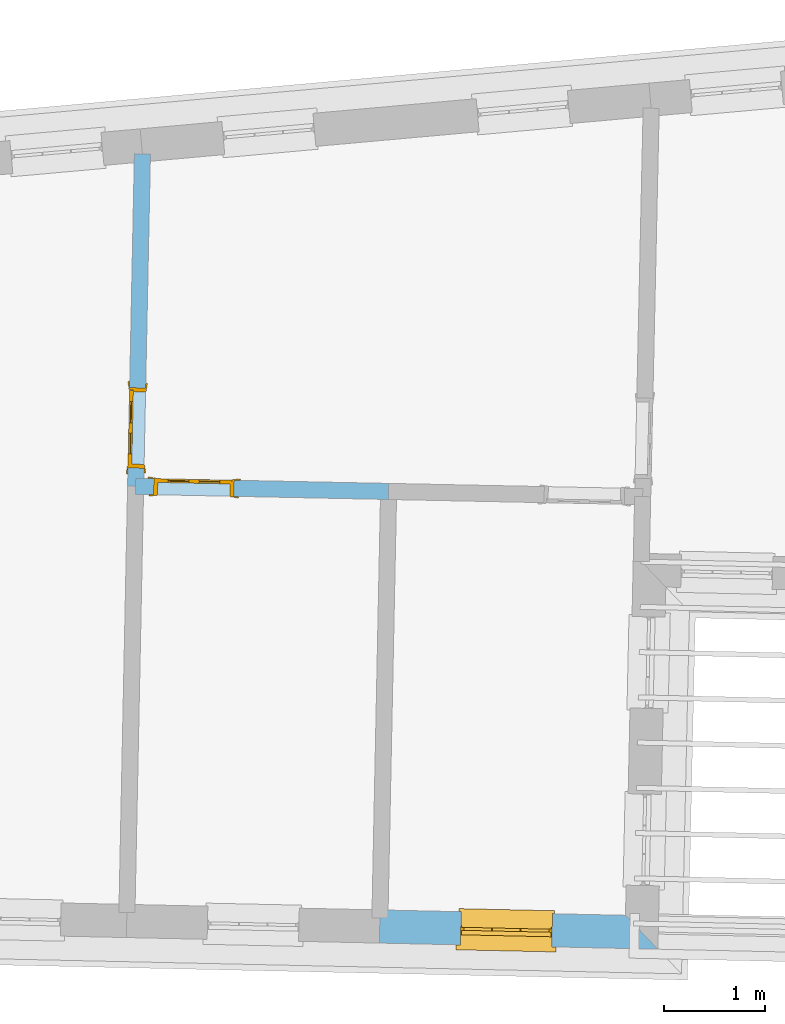
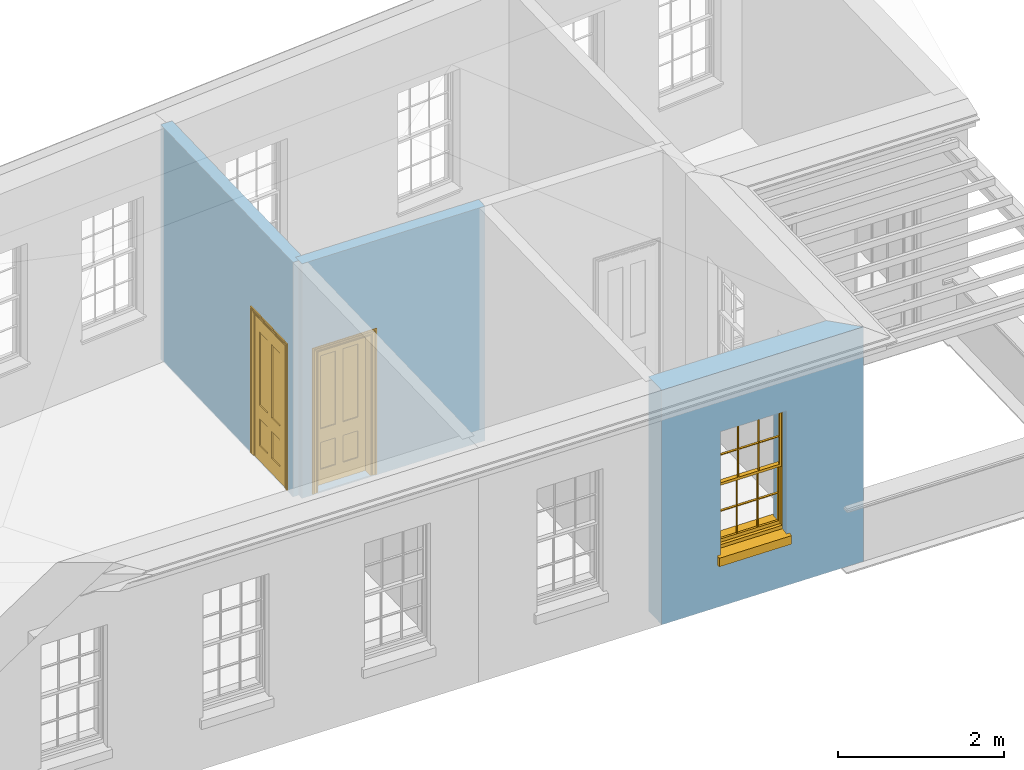
# One storey, part 7 of 14: 2 doors, 1 window, 3 openings, plus 3 elements that do not belong to this part.
"""IFC2X3 building model written with IfcOpenShell, lengths in metres."""

from ifc_helpers import new_model, si_unit, frame, origin, place, context, subcontext, project, spatial, polyline, outline, extrude, faceted_brep, material, layer, layer_set, layer_usage, element, fill, save


model = new_model("IFC2X3")

# Units and contexts
model_context = context("Model", 3, world=origin())
body_context = subcontext(model_context, "Body", "Model", "MODEL_VIEW")
ifc_project = project(units=[si_unit("PLANEANGLEUNIT", "RADIAN"), si_unit("MASSUNIT", "GRAM", prefix="KILO"), si_unit("FORCEUNIT", "NEWTON", prefix="KILO"), si_unit("LENGTHUNIT", "METRE")], contexts=[model_context])

# Site, building, storey
site_placement = place(None, origin())
site = spatial("IfcSite", under=ifc_project, at=site_placement, CompositionType="ELEMENT")
building_placement = place(None, origin())
building = spatial("IfcBuilding", under=site, at=building_placement, Name="Building plot-17", CompositionType="ELEMENT")
storey_placement = place(None, frame((0.0, 0.0, 6.15)))
storey = spatial("IfcBuildingStorey", under=building, at=storey_placement, Name="Floor 1", CompositionType="ELEMENT", Elevation=6.15)

# Wall, opening, window
ifc_material_1 = material(Name="Masonry")
ifc_layer_1 = layer(ifc_material_1, 0.33, ventilated=False)
ifc_layer_set_1 = layer_set([ifc_layer_1], Name="My Wall")
ifc_layer_usage_1 = layer_usage(ifc_layer_set_1, "AXIS2", "NEGATIVE", 0.08)
wall_1_placement = place(storey_placement, origin())
wall_1 = element("IfcWallStandardCase", 1, at=wall_1_placement, inside=storey, material=ifc_layer_usage_1, Name="exterior", context=body_context, shape_type="SweptSolid", body=[
    extrude(outline(polyline([(79.8085356769737, 18.6202146770249), (79.8013195426945, 18.2902935843284), (82.5720901936845, 18.2296904476484), (82.2493852352671, 18.5668276746241), (79.8085356769737, 18.6202146770249)])), origin(), (0.0, 0.0, 1.0), 3.45),
])
opening_1_placement = place(storey_placement, frame((0.0, 0.0, 0.75)))
opening_1 = element("IfcOpeningElement", 2, at=opening_1_placement, cuts=wall_1, Name="Opening", ObjectType="Opening", context=body_context, shape_type="SweptSolid", body=[
    extrude(outline(polyline([(80.6068435537532, 18.2726749186609), (81.516625960886, 18.2527758817093), (81.5238420951652, 18.5826969744058), (80.6140596880323, 18.6025960113574), (80.6068435537532, 18.2726749186609)])), origin(), (0.0, 0.0, 1.0), 1.82),
])
window_placement = place(storey_placement, frame((80.6123103221465, 18.5226151404007, 0.75), z_axis=(0.0, 0.0, 1.0), x_axis=(0.909782407132838, -0.0198990369516245, 0.0)))
window = element("IfcWindow", 3, at=window_placement, inside=storey, Name="toilet outside window", OverallHeight=1.82, OverallWidth=0.91, context=body_context, shape_type="Brep", held_by="IfcProductRepresentation", body=[
    faceted_brep([(0.033125, -0.105, 0.975209), (0.01, -0.105, 0.975209), (0.033125, -0.105, 1.376042), (0.876875, -0.105, 0.975209), (0.876875, -0.105, 1.376042), (0.9, -0.105, 0.975209), (0.876875, -0.105, 1.386042), (0.876875, -0.105, 1.786875), (0.9, -0.105, 1.81), (0.033125, -0.105, 1.786875), (0.033125, -0.105, 1.386042), (0.01, -0.105, 1.81), (0.876875, -0.135, 1.376042), (0.876875, -0.135, 0.975209), (0.9, -0.135, 0.937083), (0.033125, -0.135, 1.786875), (0.01, -0.135, 1.81), (0.033125, -0.135, 1.386042), (0.01, -0.135, 0.937083), (0.033125, -0.135, 0.975209), (0.033125, -0.135, 1.376042), (0.876875, -0.135, 1.786875), (0.876875, -0.135, 1.386042), (0.9, -0.135, 1.81), (0.033125, -0.105, 0.937083), (0.01, -0.105, 0.937083), (0.033125, -0.105, 0.53625), (0.876875, -0.105, 0.937083), (0.876875, -0.105, 0.53625), (0.9, -0.105, 0.937083), (0.876875, -0.105, 0.52625), (0.876875, -0.105, 0.125417), (0.9, -0.105, 0.077167), (0.033125, -0.105, 0.125417), (0.033125, -0.105, 0.52625), (0.01, -0.105, 0.077167), (-0.0425, -0.25, 0.01), (-0.0425, -0.3, 0.001667), (0.0, -0.25, 0.01), (0.9525, -0.25, 0.01), (0.91, -0.25, 0.01), (0.9525, -0.3, 0.001667), (-0.02, 0.08, 0.077167), (0.0, 0.08, 0.077167), (-0.02, 0.11, 0.077167), (0.0, -0.06, 0.077167), (0.01, -0.06, 0.077167), (0.91, -0.06, 0.077167), (0.91, 0.08, 0.077167), (0.9, -0.06, 0.077167), (0.93, 0.08, 0.077167), (0.93, 0.11, 0.077167), (0.01, -0.075, 0.975209), (0.9, -0.075, 0.975209), (0.876875, -0.075, 0.125417), (0.876875, -0.075, 0.52625), (0.9, -0.075, 0.077167), (0.876875, -0.075, 0.53625), (0.876875, -0.075, 0.937083), (0.033125, -0.075, 0.125417), (0.01, -0.075, 0.077167), (0.033125, -0.075, 0.52625), (0.033125, -0.075, 0.937083), (0.033125, -0.075, 0.53625), (-0.02, 0.08, 0.052167), (-0.02, 0.11, 0.052167), (0.93, 0.11, 0.052167), (0.93, 0.08, 0.052167), (0.91, 0.08, 0.052167), (0.0, 0.08, 0.052167), (0.91, -0.15, 0.026667), (0.0, -0.15, 0.026667), (-0.0425, -0.3, -0.123333), (0.9525, -0.3, -0.123333), (-0.0425, -0.25, -0.123333), (0.9525, -0.25, -0.123333), (0.01, -0.06, 1.81), (0.9, -0.06, 1.81), (0.0, -0.06, 1.82), (0.91, -0.06, 1.82), (0.01, -0.15, 0.077167), (0.9, -0.15, 0.077167), (0.592292, -0.105, 0.125417), (0.592292, -0.075, 0.125417), (0.317708, -0.075, 0.125417), (0.317708, -0.105, 0.125417), (0.592292, -0.105, 0.53625), (0.317708, -0.105, 0.53625), (0.317708, -0.105, 0.52625), (0.592292, -0.105, 0.52625), (0.592292, -0.075, 0.53625), (0.317708, -0.075, 0.53625), (0.592292, -0.135, 1.386042), (0.592292, -0.105, 1.386042), (0.317708, -0.105, 1.386042), (0.317708, -0.135, 1.386042), (0.317708, -0.135, 1.376042), (0.592292, -0.135, 1.376042), (0.317708, -0.105, 1.376042), (0.592292, -0.105, 1.376042), (0.602292, -0.135, 1.376042), (0.592292, -0.135, 0.975209), (0.602292, -0.135, 0.975209), (0.602292, -0.105, 0.975209), (0.592292, -0.105, 0.975209), (0.602292, -0.105, 1.376042), (0.602292, -0.075, 0.53625), (0.602292, -0.105, 0.53625), (0.317708, -0.075, 0.52625), (0.307708, -0.075, 0.125417), (0.307708, -0.075, 0.52625), (0.602292, -0.075, 0.52625), (0.602292, -0.075, 0.125417), (0.592292, -0.075, 0.52625), (0.307708, -0.075, 0.53625), (0.317708, -0.075, 0.937083), (0.307708, -0.075, 0.937083), (0.602292, -0.075, 0.937083), (0.592292, -0.075, 0.937083), (0.307708, -0.105, 0.52625), (0.307708, -0.105, 0.125417), (0.307708, -0.105, 0.53625), (0.307708, -0.105, 0.937083), (0.592292, -0.105, 0.937083), (0.317708, -0.105, 0.937083), (0.602292, -0.105, 0.937083), (0.602292, -0.105, 0.52625), (0.602292, -0.105, 0.125417), (0.307708, -0.135, 1.386042), (0.307708, -0.135, 1.376042), (0.307708, -0.135, 0.975209), (0.317708, -0.135, 0.975209), (0.317708, -0.135, 1.786875), (0.307708, -0.135, 1.786875), (0.602292, -0.135, 1.786875), (0.592292, -0.135, 1.786875), (0.602292, -0.135, 1.386042), (0.602292, -0.105, 1.386042), (0.307708, -0.105, 1.386042), (0.307708, -0.105, 1.786875), (0.317708, -0.105, 1.786875), (0.592292, -0.105, 1.786875), (0.602292, -0.105, 1.786875), (0.307708, -0.105, 1.376042), (0.317708, -0.105, 0.975209), (0.307708, -0.105, 0.975209), (0.91, -0.15, 1.82), (0.9, -0.15, 1.81), (0.01, -0.15, 1.81), (0.0, -0.15, 1.82), (0.91, -0.25, 0.0), (0.0, -0.25, 0.0), (0.91, 0.08, 0.0), (0.0, 0.08, 0.0)], [[[0, 1, 2]], [[3, 4, 5]], [[6, 7, 8]], [[9, 10, 11]], [[12, 13, 14]], [[15, 16, 17]], [[18, 19, 20]], [[21, 22, 23]], [[24, 25, 26]], [[27, 28, 29]], [[30, 31, 32]], [[33, 34, 35]], [[14, 27, 29]], [[25, 24, 18]], [[36, 37, 38]], [[39, 40, 41]], [[42, 43, 44]], [[45, 46, 43]], [[47, 48, 49]], [[50, 51, 48]], [[1, 0, 52]], [[5, 53, 3]], [[54, 55, 56]], [[57, 58, 53]], [[59, 60, 61]], [[62, 63, 52]], [[48, 43, 46, 49]], [[51, 44, 43, 48]], [[64, 42, 44, 65]], [[65, 44, 51, 66]], [[66, 51, 50, 67]], [[65, 66, 68, 69]], [[60, 56, 49, 46]], [[70, 71, 38, 40]], [[37, 41, 40, 38]], [[37, 72, 73, 41]], [[74, 75, 73, 72]], [[8, 11, 76, 77]], [[76, 78, 79, 77]], [[32, 35, 80, 81]], [[81, 80, 71, 70]], [[82, 83, 84, 85]], [[86, 87, 88, 89]], [[86, 90, 91, 87]], [[92, 93, 94, 95]], [[92, 95, 96, 97]], [[96, 98, 99, 97]], [[100, 97, 101, 102]], [[103, 104, 99, 105]], [[97, 99, 104, 101]], [[102, 103, 105, 100]], [[28, 57, 106, 107]], [[108, 84, 109, 110]], [[111, 112, 83, 113]], [[114, 110, 61, 63]], [[90, 113, 108, 91]], [[115, 91, 114, 116]], [[117, 106, 90, 118]], [[111, 106, 57, 55]], [[119, 110, 109, 120]], [[34, 61, 110, 119]], [[89, 113, 83, 82]], [[88, 108, 113, 89]], [[85, 84, 108, 88]], [[121, 114, 63, 26]], [[122, 116, 114, 121]], [[123, 118, 90, 86]], [[87, 91, 115, 124]], [[107, 106, 117, 125]], [[126, 111, 55, 30]], [[127, 112, 111, 126]], [[126, 30, 28, 107]], [[88, 119, 120, 85]], [[126, 89, 82, 127]], [[125, 123, 86, 107]], [[121, 26, 34, 119]], [[124, 122, 121, 87]], [[128, 17, 20, 129]], [[96, 129, 130, 131]], [[132, 133, 128, 95]], [[134, 135, 92, 136]], [[100, 12, 22, 136]], [[137, 6, 4, 105]], [[94, 138, 139, 140]], [[137, 93, 141, 142]], [[99, 98, 94, 93]], [[143, 2, 10, 138]], [[144, 145, 143, 98]], [[129, 143, 145, 130]], [[20, 2, 143, 129]], [[131, 144, 98, 96]], [[128, 138, 10, 17]], [[133, 139, 138, 128]], [[135, 141, 93, 92]], [[95, 94, 140, 132]], [[22, 6, 137, 136]], [[136, 137, 142, 134]], [[100, 105, 4, 12]], [[107, 86, 89, 126]], [[106, 111, 113, 90]], [[91, 108, 110, 114]], [[87, 121, 119, 88]], [[97, 100, 136, 92]], [[129, 96, 95, 128]], [[98, 143, 138, 94]], [[105, 99, 93, 137]], [[131, 101, 104, 144]], [[124, 115, 118, 123]], [[132, 140, 141, 135]], [[120, 109, 59, 33]], [[15, 9, 139, 133]], [[134, 142, 7, 21]], [[31, 54, 112, 127]], [[36, 74, 72, 37]], [[39, 41, 73, 75]], [[18, 14, 101, 131]], [[23, 16, 132, 135]], [[83, 56, 60, 84]], [[52, 53, 118, 115]], [[53, 52, 144, 104]], [[11, 8, 141, 140]], [[14, 18, 124, 123]], [[2, 1, 11, 10]], [[8, 5, 4, 6]], [[57, 53, 56, 55]], [[60, 52, 63, 61]], [[26, 25, 35, 34]], [[32, 29, 28, 30]], [[14, 23, 22, 12]], [[18, 20, 17, 16]], [[19, 0, 2, 20]], [[17, 10, 9, 15]], [[12, 4, 3, 13]], [[21, 7, 6, 22]], [[27, 58, 57, 28]], [[30, 55, 54, 31]], [[33, 59, 61, 34]], [[26, 63, 62, 24]], [[5, 8, 77, 53]], [[76, 11, 1, 52]], [[46, 45, 78, 76]], [[49, 77, 79, 47]], [[70, 146, 147, 81]], [[71, 80, 148, 149]], [[19, 130, 145, 0]], [[102, 13, 3, 103]], [[116, 122, 24, 62]], [[29, 32, 81, 14]], [[80, 35, 25, 18]], [[60, 46, 76, 52]], [[77, 49, 56, 53]], [[23, 14, 81, 147]], [[16, 148, 80, 18]], [[35, 85, 120]], [[120, 33, 35]], [[127, 82, 32]], [[32, 31, 127]], [[32, 82, 85, 35]], [[102, 101, 14]], [[14, 13, 102]], [[18, 131, 130]], [[130, 19, 18]], [[134, 21, 23]], [[23, 135, 134]], [[16, 15, 133]], [[133, 132, 16]], [[11, 140, 139]], [[139, 9, 11]], [[142, 141, 8]], [[8, 7, 142]], [[23, 147, 148, 16]], [[146, 149, 148, 147]], [[52, 115, 116]], [[116, 62, 52]], [[118, 53, 117]], [[58, 117, 53]], [[27, 125, 117, 58]], [[56, 83, 112]], [[112, 54, 56]], [[109, 84, 60]], [[60, 59, 109]], [[125, 27, 14]], [[14, 123, 125]], [[122, 124, 18]], [[18, 24, 122]], [[145, 144, 52]], [[52, 0, 145]], [[103, 3, 53]], [[53, 104, 103]], [[79, 78, 149, 146]], [[78, 45, 71, 149]], [[146, 70, 47, 79]], [[150, 75, 74, 151]], [[68, 66, 67]], [[48, 68, 67, 50]], [[69, 64, 65]], [[42, 64, 69, 43]], [[69, 68, 152, 153]], [[70, 68, 48, 47]], [[150, 152, 68, 70]], [[43, 69, 71, 45]], [[69, 153, 151, 71]], [[152, 150, 151, 153]], [[38, 151, 74, 36]], [[71, 151, 38]], [[39, 75, 150, 40]], [[40, 150, 70]]]),
])
fill(opening_1, window)

# Wall, opening, door
ifc_material_2 = material(Name="Masonry")
ifc_layer_2 = layer(ifc_material_2, 0.16, ventilated=False)
ifc_layer_set_2 = layer_set([ifc_layer_2], Name="My Wall")
ifc_layer_usage_2 = layer_usage(ifc_layer_set_2, "AXIS2", "NEGATIVE", 0.08)
wall_2_placement = place(storey_placement, origin())
wall_2 = element("IfcWallStandardCase", 4, at=wall_2_placement, inside=storey, material=ifc_layer_usage_2, Name="interior", context=body_context, shape_type="SweptSolid", body=[
    extrude(outline(polyline([(77.3784779679642, 22.9142083412841), (77.3752122822302, 22.7542416719537), (79.8917655829418, 22.702866768374), (79.8950312686758, 22.8628334377044), (77.3784779679642, 22.9142083412841)])), origin(), (0.0, 0.0, 1.0), 3.45),
])
opening_2_placement = place(storey_placement, frame((0.0, 0.0, 0.0199999999999996)))
opening_2 = element("IfcOpeningElement", 5, at=opening_2_placement, cuts=wall_2, Name="Opening", ObjectType="Opening", context=body_context, shape_type="SweptSolid", body=[
    extrude(outline(polyline([(77.555174785227, 22.750567775503), (78.3550081318794, 22.7342393468333), (78.3582738176134, 22.8942060161638), (77.558440470961, 22.9105344448335), (77.555174785227, 22.750567775503)])), origin(), (0.0, 0.0, 1.0), 2.1),
])
door_1_placement = place(storey_placement, frame((77.556807628094, 22.8305511101682, 0.0199999999999996), z_axis=(0.0, 0.0, 1.0), x_axis=(0.799833346652406, -0.0163284286696737, 0.0)))
door_1 = element("IfcDoor", 6, at=door_1_placement, inside=storey, Name="bedroom inside door", OverallHeight=2.1, OverallWidth=0.8, context=body_context, shape_type="Brep", held_by="IfcProductRepresentation", body=[
    faceted_brep([(0.773, 0.08, 1.895), (0.66, 0.08, 1.895), (0.66, 0.08, 2.073), (0.773, 0.08, 2.073), (0.773, 0.08, 0.82), (0.66, 0.08, 0.82), (0.45, 0.08, 1.895), (0.45, 0.08, 2.073), (0.773, 0.08, 0.62), (0.66, 0.08, 0.62), (0.66, 0.065, 0.82), (0.66, 0.065, 1.895), (0.45, 0.065, 1.895), (0.35, 0.08, 1.895), (0.35, 0.08, 2.073), (0.773, 0.08, 0.225), (0.66, 0.08, 0.225), (0.45, 0.08, 0.62), (0.45, 0.08, 0.82), (0.45, 0.065, 0.82), (0.35, 0.08, 0.82), (0.14, 0.08, 2.073), (0.14, 0.08, 1.895), (0.773, 0.08, 0.0), (0.66, 0.08, 0.0), (0.66, 0.065, 0.225), (0.66, 0.065, 0.62), (0.45, 0.065, 0.62), (0.35, 0.08, 0.62), (0.35, 0.065, 0.82), (0.35, 0.065, 1.895), (0.14, 0.065, 1.895), (0.027, 0.08, 2.073), (0.027, 0.08, 1.895), (0.773, 0.042, 0.0), (0.66, 0.042, 0.0), (0.45, 0.08, 0.0), (0.45, 0.08, 0.225), (0.45, 0.065, 0.225), (0.35, 0.08, 0.225), (0.14, 0.08, 0.82), (0.14, 0.08, 0.62), (0.14, 0.065, 0.82), (0.027, 0.08, 0.82), (0.773, 0.042, 0.225), (0.66, 0.042, 0.225), (0.45, 0.042, 0.0), (0.35, 0.08, 0.0), (0.35, 0.065, 0.225), (0.35, 0.065, 0.62), (0.14, 0.065, 0.62), (0.027, 0.08, 0.62), (0.773, 0.042, 0.62), (0.66, 0.042, 0.62), (0.45, 0.042, 0.225), (0.35, 0.042, 0.0), (0.14, 0.08, 0.225), (0.14, 0.08, 0.0), (0.14, 0.065, 0.225), (0.027, 0.08, 0.225), (0.773, 0.042, 0.82), (0.66, 0.042, 0.82), (0.66, 0.057, 0.62), (0.66, 0.057, 0.225), (0.45, 0.057, 0.225), (0.35, 0.042, 0.225), (0.14, 0.042, 0.0), (0.027, 0.08, 0.0), (0.773, 0.042, 1.895), (0.66, 0.042, 1.895), (0.45, 0.042, 0.62), (0.45, 0.042, 0.82), (0.45, 0.057, 0.62), (0.35, 0.042, 0.62), (0.14, 0.042, 0.225), (0.027, 0.042, 0.0), (0.773, 0.042, 2.073), (0.66, 0.042, 2.073), (0.66, 0.057, 1.895), (0.66, 0.057, 0.82), (0.45, 0.057, 0.82), (0.35, 0.042, 0.82), (0.35, 0.057, 0.62), (0.35, 0.057, 0.225), (0.14, 0.057, 0.225), (0.027, 0.042, 0.225), (0.45, 0.042, 1.895), (0.45, 0.042, 2.073), (0.45, 0.057, 1.895), (0.35, 0.042, 1.895), (0.14, 0.042, 0.82), (0.14, 0.042, 0.62), (0.14, 0.057, 0.62), (0.027, 0.042, 0.62), (0.35, 0.042, 2.073), (0.35, 0.057, 1.895), (0.35, 0.057, 0.82), (0.14, 0.057, 0.82), (0.027, 0.042, 0.82), (0.14, 0.042, 2.073), (0.14, 0.042, 1.895), (0.14, 0.057, 1.895), (0.027, 0.042, 1.895), (0.027, 0.042, 2.073), (0.02, 0.085, 0.0), (0.005, 0.09, 0.0), (0.005, 0.09, 2.095), (0.02, 0.085, 2.08), (0.02, 0.08, 0.0), (0.0, 0.085, 0.0), (0.0, 0.085, 2.1), (0.795, 0.09, 2.095), (0.78, 0.085, 2.08), (0.02, 0.08, 2.08), (0.0, 0.08, 0.0), (-0.032, 0.095, 0.0), (-0.032, 0.095, 2.132), (0.8, 0.085, 2.1), (0.795, 0.09, 0.0), (0.78, 0.085, 0.0), (0.78, 0.08, 2.08), (0.04, 0.04, 0.0), (0.025, 0.04, 0.0), (0.025, 0.04, 2.075), (0.04, 0.04, 2.06), (-0.04, 0.09, 0.0), (-0.04, 0.09, 2.14), (0.832, 0.095, 2.132), (0.8, 0.085, 0.0), (0.78, 0.08, 0.0), (0.8, 0.08, 0.0), (0.86, 0.08, 0.0), (0.86, 0.08, 2.16), (0.8, 0.08, 2.1), (-0.06, 0.08, 2.16), (0.0, 0.08, 2.1), (-0.06, 0.08, 0.0), (-0.04, 0.095, 0.0), (-0.04, 0.095, 2.14), (0.84, 0.09, 2.14), (0.832, 0.095, 0.0), (0.84, 0.09, 0.0), (0.86, 0.095, 0.0), (0.86, 0.095, 2.16), (-0.06, 0.095, 2.16), (-0.06, 0.095, 0.0), (0.84, 0.095, 0.0), (0.84, 0.095, 2.14), (-0.025, -0.095, 0.0), (-0.025, -0.09, 0.0), (-0.025, -0.09, 2.125), (-0.025, -0.095, 2.125), (-0.017, -0.095, 0.0), (-0.017, -0.095, 2.117), (0.825, -0.09, 2.125), (0.825, -0.095, 2.125), (0.825, -0.095, 0.0), (0.845, -0.095, 0.0), (-0.045, -0.095, 2.145), (-0.045, -0.095, 0.0), (0.845, -0.095, 2.145), (0.015, -0.085, 0.0), (0.015, -0.085, 2.085), (0.817, -0.095, 2.117), (0.825, -0.09, 0.0), (0.845, -0.08, 0.0), (0.845, -0.08, 2.145), (-0.045, -0.08, 2.145), (-0.045, -0.08, 0.0), (0.02, -0.09, 0.0), (0.02, -0.09, 2.08), (0.785, -0.085, 2.085), (0.817, -0.095, 0.0), (0.8, -0.08, 0.0), (0.8, -0.08, 2.1), (0.0, -0.08, 2.1), (0.0, -0.08, 0.0), (0.035, -0.085, 0.0), (0.035, -0.085, 2.065), (0.78, -0.09, 2.08), (0.785, -0.085, 0.0), (0.775, 0.04, 2.075), (0.76, 0.04, 2.06), (0.035, -0.08, 2.065), (0.035, -0.08, 0.0), (0.765, -0.085, 2.065), (0.78, -0.09, 0.0), (0.765, -0.08, 0.0), (0.765, -0.08, 2.065), (0.765, -0.085, 0.0), (0.04, -0.08, 2.06), (0.04, -0.08, 0.0), (0.76, -0.08, 2.06), (0.76, -0.08, 0.0), (0.76, 0.04, 0.0), (0.775, 0.04, 0.0), (0.025, 0.08, 0.0), (0.025, 0.08, 2.075), (0.775, 0.08, 0.0), (0.775, 0.08, 2.075)], [[[0, 1, 2, 3]], [[1, 0, 4, 5]], [[1, 6, 7, 2]], [[8, 9, 5, 4]], [[1, 5, 10, 11]], [[6, 1, 11, 12]], [[6, 13, 14, 7]], [[15, 16, 9, 8]], [[9, 17, 18, 5]], [[5, 18, 19, 10]], [[10, 19, 12, 11]], [[18, 6, 12, 19]], [[18, 20, 13, 6]], [[21, 14, 13, 22]], [[23, 24, 16, 15]], [[9, 16, 25, 26]], [[17, 9, 26, 27]], [[17, 28, 20, 18]], [[13, 20, 29, 30]], [[22, 13, 30, 31]], [[32, 21, 22, 33]], [[34, 35, 24, 23]], [[24, 36, 37, 16]], [[16, 37, 38, 25]], [[25, 38, 27, 26]], [[37, 17, 27, 38]], [[37, 39, 28, 17]], [[40, 20, 28, 41]], [[20, 40, 42, 29]], [[31, 30, 29, 42]], [[40, 22, 31, 42]], [[33, 22, 40, 43]], [[35, 34, 44, 45]], [[35, 46, 36, 24]], [[36, 47, 39, 37]], [[28, 39, 48, 49]], [[41, 28, 49, 50]], [[43, 40, 41, 51]], [[45, 44, 52, 53]], [[46, 35, 45, 54]], [[46, 55, 47, 36]], [[56, 39, 47, 57]], [[39, 56, 58, 48]], [[50, 49, 48, 58]], [[56, 41, 50, 58]], [[51, 41, 56, 59]], [[53, 52, 60, 61]], [[45, 53, 62, 63]], [[54, 45, 63, 64]], [[55, 46, 54, 65]], [[55, 66, 57, 47]], [[59, 56, 57, 67]], [[61, 60, 68, 69]], [[70, 53, 61, 71]], [[53, 70, 72, 62]], [[72, 64, 63, 62]], [[70, 54, 64, 72]], [[65, 54, 70, 73]], [[65, 74, 66, 55]], [[67, 57, 66, 75]], [[69, 68, 76, 77]], [[61, 69, 78, 79]], [[71, 61, 79, 80]], [[73, 70, 71, 81]], [[65, 73, 82, 83]], [[74, 65, 83, 84]], [[74, 85, 75, 66]], [[86, 69, 77, 87]], [[69, 86, 88, 78]], [[88, 80, 79, 78]], [[86, 71, 80, 88]], [[81, 71, 86, 89]], [[73, 81, 90, 91]], [[73, 91, 92, 82]], [[83, 82, 92, 84]], [[91, 74, 84, 92]], [[91, 93, 85, 74]], [[89, 86, 87, 94]], [[81, 89, 95, 96]], [[90, 81, 96, 97]], [[90, 98, 93, 91]], [[94, 99, 100, 89]], [[89, 100, 101, 95]], [[101, 97, 96, 95]], [[100, 90, 97, 101]], [[100, 102, 98, 90]], [[99, 103, 102, 100]], [[32, 103, 99, 21]], [[102, 103, 32, 33]], [[98, 102, 33, 43]], [[21, 99, 94, 14]], [[94, 87, 7, 14]], [[7, 87, 77, 2]], [[76, 3, 2, 77]], [[43, 51, 93, 98]], [[51, 59, 85, 93]], [[67, 75, 85, 59]], [[34, 23, 15, 44]], [[44, 15, 8, 52]], [[52, 8, 4, 60]], [[0, 68, 60, 4]], [[0, 3, 76, 68]], [[104, 105, 106, 107]], [[104, 108, 109, 105]], [[105, 109, 110, 106]], [[107, 106, 111, 112]], [[107, 113, 108, 104]], [[114, 109, 108]], [[109, 115, 116, 110]], [[106, 110, 117, 111]], [[112, 111, 118, 119]], [[113, 107, 112, 120]], [[121, 122, 123, 124]], [[115, 109, 114, 125]], [[115, 125, 126, 116]], [[110, 116, 127, 117]], [[111, 117, 128, 118]], [[118, 128, 129, 119]], [[120, 112, 119, 129]], [[130, 129, 128]], [[130, 131, 132, 133]], [[133, 132, 134, 135]], [[135, 134, 136, 114]], [[136, 125, 114]], [[125, 137, 138, 126]], [[116, 126, 139, 127]], [[117, 127, 140, 128]], [[141, 130, 128, 140]], [[131, 130, 141]], [[131, 142, 143, 132]], [[132, 143, 144, 134]], [[134, 144, 145, 136]], [[137, 125, 136, 145]], [[143, 142, 146]], [[143, 146, 147]], [[137, 145, 144]], [[143, 147, 138]], [[138, 137, 144]], [[143, 138, 144]], [[126, 138, 147, 139]], [[127, 139, 141, 140]], [[142, 131, 141, 146]], [[139, 147, 146, 141]], [[148, 149, 150, 151]], [[149, 152, 153, 150]], [[151, 150, 154, 155]], [[155, 156, 157]], [[158, 159, 148]], [[158, 148, 151]], [[155, 157, 160]], [[158, 151, 155]], [[155, 160, 158]], [[152, 161, 162, 153]], [[150, 153, 163, 154]], [[155, 154, 164, 156]], [[156, 164, 165, 157]], [[157, 165, 166, 160]], [[160, 166, 167, 158]], [[158, 167, 168, 159]], [[161, 169, 170, 162]], [[153, 162, 171, 163]], [[154, 163, 172, 164]], [[165, 164, 173]], [[165, 173, 174, 166]], [[166, 174, 175, 167]], [[167, 175, 176, 168]], [[169, 177, 178, 170]], [[162, 170, 179, 171]], [[163, 171, 180, 172]], [[172, 180, 173, 164]], [[124, 123, 181, 182]], [[183, 178, 177, 184]], [[170, 178, 185, 179]], [[171, 179, 186, 180]], [[187, 173, 180]], [[185, 188, 187, 189]], [[188, 185, 178, 183]], [[179, 185, 189, 186]], [[189, 187, 180, 186]], [[190, 183, 184, 191]], [[192, 188, 183, 190]], [[191, 184, 122, 121]], [[124, 190, 191, 121]], [[193, 187, 188, 192]], [[182, 192, 190, 124]], [[184, 176, 122]], [[194, 195, 187, 193]], [[192, 182, 194, 193]], [[161, 176, 184]], [[114, 108, 122, 176]], [[173, 187, 195]], [[152, 149, 176, 161]], [[169, 161, 184, 177]], [[196, 122, 108]], [[176, 175, 135, 114]], [[173, 195, 129, 130]], [[176, 149, 168]], [[123, 122, 196, 197]], [[196, 108, 113, 197]], [[175, 174, 133, 135]], [[198, 129, 195]], [[133, 174, 173, 130]], [[159, 168, 149, 148]], [[181, 123, 197, 199]], [[197, 113, 120, 199]], [[199, 120, 129, 198]], [[195, 181, 199, 198]], [[195, 194, 182, 181]]]),
])
fill(opening_2, door_1)

wall_3_placement = place(storey_placement, origin())
wall_3 = element("IfcWallStandardCase", 7, at=wall_3_placement, inside=storey, material=ifc_layer_usage_2, Name="interior", context=body_context, shape_type="SweptSolid", body=[
    extrude(outline(polyline([(77.296861790432, 22.8358578494859), (77.4568284597624, 22.8325921637519), (77.5243236632891, 26.138783813413), (77.3643569939587, 26.142049499147), (77.296861790432, 22.8358578494859)])), origin(), (0.0, 0.0, 1.0), 3.45),
])
opening_3_placement = place(storey_placement, frame((0.0, 0.0, 0.0199999999999996)))
opening_3 = element("IfcOpeningElement", 8, at=opening_3_placement, cuts=wall_3, Name="Opening", ObjectType="Opening", context=body_context, shape_type="SweptSolid", body=[
    extrude(outline(polyline([(77.4605023562131, 23.0125546667487), (77.4768307848828, 23.8123880134011), (77.3168641155523, 23.8156536991351), (77.3005356868826, 23.0158203524827), (77.4605023562131, 23.0125546667487)])), origin(), (0.0, 0.0, 1.0), 2.1),
])
door_2_placement = place(storey_placement, frame((77.3805190215479, 23.0141875096157, 0.0199999999999996), z_axis=(0.0, 0.0, 1.0), x_axis=(0.0163284286696666, 0.799833346652399, 0.0)))
door_2 = element("IfcDoor", 9, at=door_2_placement, inside=storey, Name="bedroom inside door", OverallHeight=2.1, OverallWidth=0.8, context=body_context, shape_type="Brep", held_by="IfcProductRepresentation", body=[
    faceted_brep([(0.773, 0.08, 1.895), (0.66, 0.08, 1.895), (0.66, 0.08, 2.073), (0.773, 0.08, 2.073), (0.773, 0.08, 0.82), (0.66, 0.08, 0.82), (0.45, 0.08, 1.895), (0.45, 0.08, 2.073), (0.773, 0.08, 0.62), (0.66, 0.08, 0.62), (0.66, 0.065, 0.82), (0.66, 0.065, 1.895), (0.45, 0.065, 1.895), (0.35, 0.08, 1.895), (0.35, 0.08, 2.073), (0.773, 0.08, 0.225), (0.66, 0.08, 0.225), (0.45, 0.08, 0.62), (0.45, 0.08, 0.82), (0.45, 0.065, 0.82), (0.35, 0.08, 0.82), (0.14, 0.08, 2.073), (0.14, 0.08, 1.895), (0.773, 0.08, 0.0), (0.66, 0.08, 0.0), (0.66, 0.065, 0.225), (0.66, 0.065, 0.62), (0.45, 0.065, 0.62), (0.35, 0.08, 0.62), (0.35, 0.065, 0.82), (0.35, 0.065, 1.895), (0.14, 0.065, 1.895), (0.027, 0.08, 2.073), (0.027, 0.08, 1.895), (0.773, 0.042, 0.0), (0.66, 0.042, 0.0), (0.45, 0.08, 0.0), (0.45, 0.08, 0.225), (0.45, 0.065, 0.225), (0.35, 0.08, 0.225), (0.14, 0.08, 0.82), (0.14, 0.08, 0.62), (0.14, 0.065, 0.82), (0.027, 0.08, 0.82), (0.773, 0.042, 0.225), (0.66, 0.042, 0.225), (0.45, 0.042, 0.0), (0.35, 0.08, 0.0), (0.35, 0.065, 0.225), (0.35, 0.065, 0.62), (0.14, 0.065, 0.62), (0.027, 0.08, 0.62), (0.773, 0.042, 0.62), (0.66, 0.042, 0.62), (0.45, 0.042, 0.225), (0.35, 0.042, 0.0), (0.14, 0.08, 0.225), (0.14, 0.08, 0.0), (0.14, 0.065, 0.225), (0.027, 0.08, 0.225), (0.773, 0.042, 0.82), (0.66, 0.042, 0.82), (0.66, 0.057, 0.62), (0.66, 0.057, 0.225), (0.45, 0.057, 0.225), (0.35, 0.042, 0.225), (0.14, 0.042, 0.0), (0.027, 0.08, 0.0), (0.773, 0.042, 1.895), (0.66, 0.042, 1.895), (0.45, 0.042, 0.62), (0.45, 0.042, 0.82), (0.45, 0.057, 0.62), (0.35, 0.042, 0.62), (0.14, 0.042, 0.225), (0.027, 0.042, 0.0), (0.773, 0.042, 2.073), (0.66, 0.042, 2.073), (0.66, 0.057, 1.895), (0.66, 0.057, 0.82), (0.45, 0.057, 0.82), (0.35, 0.042, 0.82), (0.35, 0.057, 0.62), (0.35, 0.057, 0.225), (0.14, 0.057, 0.225), (0.027, 0.042, 0.225), (0.45, 0.042, 1.895), (0.45, 0.042, 2.073), (0.45, 0.057, 1.895), (0.35, 0.042, 1.895), (0.14, 0.042, 0.82), (0.14, 0.042, 0.62), (0.14, 0.057, 0.62), (0.027, 0.042, 0.62), (0.35, 0.042, 2.073), (0.35, 0.057, 1.895), (0.35, 0.057, 0.82), (0.14, 0.057, 0.82), (0.027, 0.042, 0.82), (0.14, 0.042, 2.073), (0.14, 0.042, 1.895), (0.14, 0.057, 1.895), (0.027, 0.042, 1.895), (0.027, 0.042, 2.073), (0.02, 0.085, 0.0), (0.005, 0.09, 0.0), (0.005, 0.09, 2.095), (0.02, 0.085, 2.08), (0.02, 0.08, 0.0), (0.0, 0.085, 0.0), (0.0, 0.085, 2.1), (0.795, 0.09, 2.095), (0.78, 0.085, 2.08), (0.02, 0.08, 2.08), (0.0, 0.08, 0.0), (-0.032, 0.095, 0.0), (-0.032, 0.095, 2.132), (0.8, 0.085, 2.1), (0.795, 0.09, 0.0), (0.78, 0.085, 0.0), (0.78, 0.08, 2.08), (0.04, 0.04, 0.0), (0.025, 0.04, 0.0), (0.025, 0.04, 2.075), (0.04, 0.04, 2.06), (-0.04, 0.09, 0.0), (-0.04, 0.09, 2.14), (0.832, 0.095, 2.132), (0.8, 0.085, 0.0), (0.78, 0.08, 0.0), (0.8, 0.08, 0.0), (0.86, 0.08, 0.0), (0.86, 0.08, 2.16), (0.8, 0.08, 2.1), (-0.06, 0.08, 2.16), (0.0, 0.08, 2.1), (-0.06, 0.08, 0.0), (-0.04, 0.095, 0.0), (-0.04, 0.095, 2.14), (0.84, 0.09, 2.14), (0.832, 0.095, 0.0), (0.84, 0.09, 0.0), (0.86, 0.095, 0.0), (0.86, 0.095, 2.16), (-0.06, 0.095, 2.16), (-0.06, 0.095, 0.0), (0.84, 0.095, 0.0), (0.84, 0.095, 2.14), (-0.025, -0.095, 0.0), (-0.025, -0.09, 0.0), (-0.025, -0.09, 2.125), (-0.025, -0.095, 2.125), (-0.017, -0.095, 0.0), (-0.017, -0.095, 2.117), (0.825, -0.09, 2.125), (0.825, -0.095, 2.125), (0.825, -0.095, 0.0), (0.845, -0.095, 0.0), (-0.045, -0.095, 2.145), (-0.045, -0.095, 0.0), (0.845, -0.095, 2.145), (0.015, -0.085, 0.0), (0.015, -0.085, 2.085), (0.817, -0.095, 2.117), (0.825, -0.09, 0.0), (0.845, -0.08, 0.0), (0.845, -0.08, 2.145), (-0.045, -0.08, 2.145), (-0.045, -0.08, 0.0), (0.02, -0.09, 0.0), (0.02, -0.09, 2.08), (0.785, -0.085, 2.085), (0.817, -0.095, 0.0), (0.8, -0.08, 0.0), (0.8, -0.08, 2.1), (0.0, -0.08, 2.1), (0.0, -0.08, 0.0), (0.035, -0.085, 0.0), (0.035, -0.085, 2.065), (0.78, -0.09, 2.08), (0.785, -0.085, 0.0), (0.775, 0.04, 2.075), (0.76, 0.04, 2.06), (0.035, -0.08, 2.065), (0.035, -0.08, 0.0), (0.765, -0.085, 2.065), (0.78, -0.09, 0.0), (0.765, -0.08, 0.0), (0.765, -0.08, 2.065), (0.765, -0.085, 0.0), (0.04, -0.08, 2.06), (0.04, -0.08, 0.0), (0.76, -0.08, 2.06), (0.76, -0.08, 0.0), (0.76, 0.04, 0.0), (0.775, 0.04, 0.0), (0.025, 0.08, 0.0), (0.025, 0.08, 2.075), (0.775, 0.08, 0.0), (0.775, 0.08, 2.075)], [[[0, 1, 2, 3]], [[1, 0, 4, 5]], [[1, 6, 7, 2]], [[8, 9, 5, 4]], [[1, 5, 10, 11]], [[6, 1, 11, 12]], [[6, 13, 14, 7]], [[15, 16, 9, 8]], [[9, 17, 18, 5]], [[5, 18, 19, 10]], [[10, 19, 12, 11]], [[18, 6, 12, 19]], [[18, 20, 13, 6]], [[21, 14, 13, 22]], [[23, 24, 16, 15]], [[9, 16, 25, 26]], [[17, 9, 26, 27]], [[17, 28, 20, 18]], [[13, 20, 29, 30]], [[22, 13, 30, 31]], [[32, 21, 22, 33]], [[34, 35, 24, 23]], [[24, 36, 37, 16]], [[16, 37, 38, 25]], [[25, 38, 27, 26]], [[37, 17, 27, 38]], [[37, 39, 28, 17]], [[40, 20, 28, 41]], [[20, 40, 42, 29]], [[31, 30, 29, 42]], [[40, 22, 31, 42]], [[33, 22, 40, 43]], [[35, 34, 44, 45]], [[35, 46, 36, 24]], [[36, 47, 39, 37]], [[28, 39, 48, 49]], [[41, 28, 49, 50]], [[43, 40, 41, 51]], [[45, 44, 52, 53]], [[46, 35, 45, 54]], [[46, 55, 47, 36]], [[56, 39, 47, 57]], [[39, 56, 58, 48]], [[50, 49, 48, 58]], [[56, 41, 50, 58]], [[51, 41, 56, 59]], [[53, 52, 60, 61]], [[45, 53, 62, 63]], [[54, 45, 63, 64]], [[55, 46, 54, 65]], [[55, 66, 57, 47]], [[59, 56, 57, 67]], [[61, 60, 68, 69]], [[70, 53, 61, 71]], [[53, 70, 72, 62]], [[72, 64, 63, 62]], [[70, 54, 64, 72]], [[65, 54, 70, 73]], [[65, 74, 66, 55]], [[67, 57, 66, 75]], [[69, 68, 76, 77]], [[61, 69, 78, 79]], [[71, 61, 79, 80]], [[73, 70, 71, 81]], [[65, 73, 82, 83]], [[74, 65, 83, 84]], [[74, 85, 75, 66]], [[86, 69, 77, 87]], [[69, 86, 88, 78]], [[88, 80, 79, 78]], [[86, 71, 80, 88]], [[81, 71, 86, 89]], [[73, 81, 90, 91]], [[73, 91, 92, 82]], [[83, 82, 92, 84]], [[91, 74, 84, 92]], [[91, 93, 85, 74]], [[89, 86, 87, 94]], [[81, 89, 95, 96]], [[90, 81, 96, 97]], [[90, 98, 93, 91]], [[94, 99, 100, 89]], [[89, 100, 101, 95]], [[101, 97, 96, 95]], [[100, 90, 97, 101]], [[100, 102, 98, 90]], [[99, 103, 102, 100]], [[32, 103, 99, 21]], [[102, 103, 32, 33]], [[98, 102, 33, 43]], [[21, 99, 94, 14]], [[94, 87, 7, 14]], [[7, 87, 77, 2]], [[76, 3, 2, 77]], [[43, 51, 93, 98]], [[51, 59, 85, 93]], [[67, 75, 85, 59]], [[34, 23, 15, 44]], [[44, 15, 8, 52]], [[52, 8, 4, 60]], [[0, 68, 60, 4]], [[0, 3, 76, 68]], [[104, 105, 106, 107]], [[104, 108, 109, 105]], [[105, 109, 110, 106]], [[107, 106, 111, 112]], [[107, 113, 108, 104]], [[114, 109, 108]], [[109, 115, 116, 110]], [[106, 110, 117, 111]], [[112, 111, 118, 119]], [[113, 107, 112, 120]], [[121, 122, 123, 124]], [[115, 109, 114, 125]], [[115, 125, 126, 116]], [[110, 116, 127, 117]], [[111, 117, 128, 118]], [[118, 128, 129, 119]], [[120, 112, 119, 129]], [[130, 129, 128]], [[130, 131, 132, 133]], [[133, 132, 134, 135]], [[135, 134, 136, 114]], [[136, 125, 114]], [[125, 137, 138, 126]], [[116, 126, 139, 127]], [[117, 127, 140, 128]], [[141, 130, 128, 140]], [[131, 130, 141]], [[131, 142, 143, 132]], [[132, 143, 144, 134]], [[134, 144, 145, 136]], [[137, 125, 136, 145]], [[143, 142, 146]], [[143, 146, 147]], [[137, 145, 144]], [[143, 147, 138]], [[138, 137, 144]], [[143, 138, 144]], [[126, 138, 147, 139]], [[127, 139, 141, 140]], [[142, 131, 141, 146]], [[139, 147, 146, 141]], [[148, 149, 150, 151]], [[149, 152, 153, 150]], [[151, 150, 154, 155]], [[155, 156, 157]], [[158, 159, 148]], [[158, 148, 151]], [[155, 157, 160]], [[158, 151, 155]], [[155, 160, 158]], [[152, 161, 162, 153]], [[150, 153, 163, 154]], [[155, 154, 164, 156]], [[156, 164, 165, 157]], [[157, 165, 166, 160]], [[160, 166, 167, 158]], [[158, 167, 168, 159]], [[161, 169, 170, 162]], [[153, 162, 171, 163]], [[154, 163, 172, 164]], [[165, 164, 173]], [[165, 173, 174, 166]], [[166, 174, 175, 167]], [[167, 175, 176, 168]], [[169, 177, 178, 170]], [[162, 170, 179, 171]], [[163, 171, 180, 172]], [[172, 180, 173, 164]], [[124, 123, 181, 182]], [[183, 178, 177, 184]], [[170, 178, 185, 179]], [[171, 179, 186, 180]], [[187, 173, 180]], [[185, 188, 187, 189]], [[188, 185, 178, 183]], [[179, 185, 189, 186]], [[189, 187, 180, 186]], [[190, 183, 184, 191]], [[192, 188, 183, 190]], [[191, 184, 122, 121]], [[124, 190, 191, 121]], [[193, 187, 188, 192]], [[182, 192, 190, 124]], [[184, 176, 122]], [[194, 195, 187, 193]], [[192, 182, 194, 193]], [[161, 176, 184]], [[114, 108, 122, 176]], [[173, 187, 195]], [[152, 149, 176, 161]], [[169, 161, 184, 177]], [[196, 122, 108]], [[176, 175, 135, 114]], [[173, 195, 129, 130]], [[176, 149, 168]], [[123, 122, 196, 197]], [[196, 108, 113, 197]], [[175, 174, 133, 135]], [[198, 129, 195]], [[133, 174, 173, 130]], [[159, 168, 149, 148]], [[181, 123, 197, 199]], [[197, 113, 120, 199]], [[199, 120, 129, 198]], [[195, 181, 199, 198]], [[195, 194, 182, 181]]]),
])
fill(opening_3, door_2)

save(model, "model.ifc")
